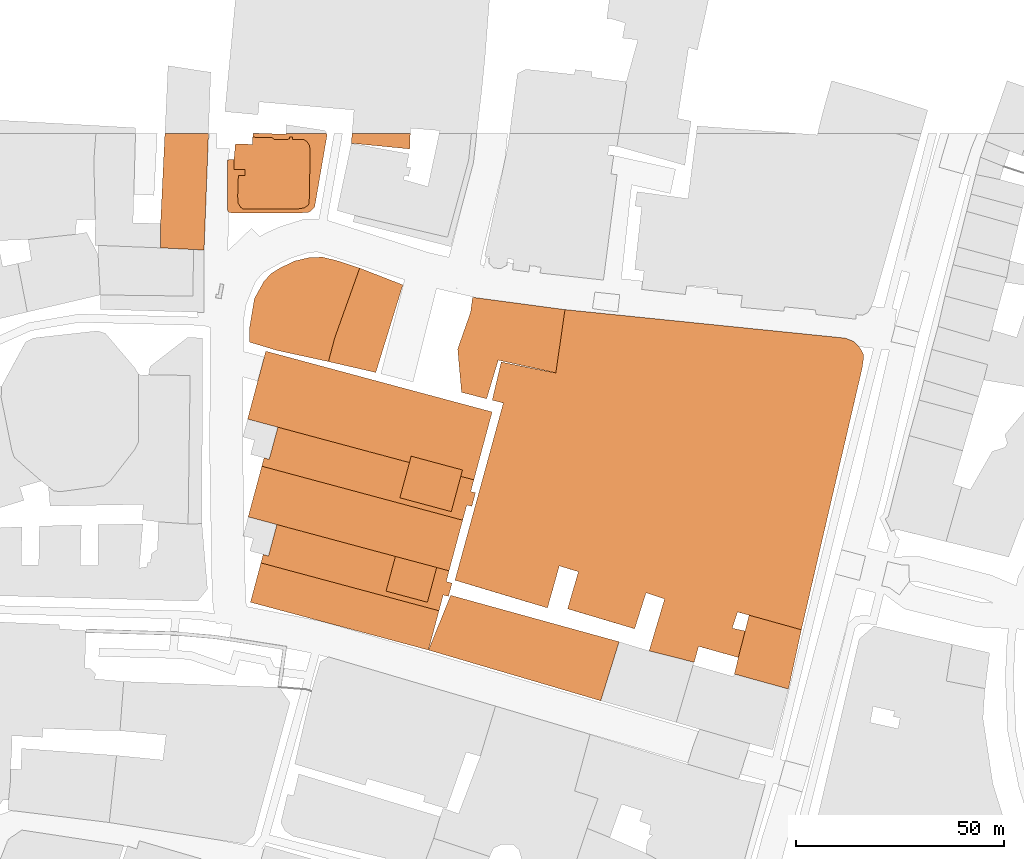
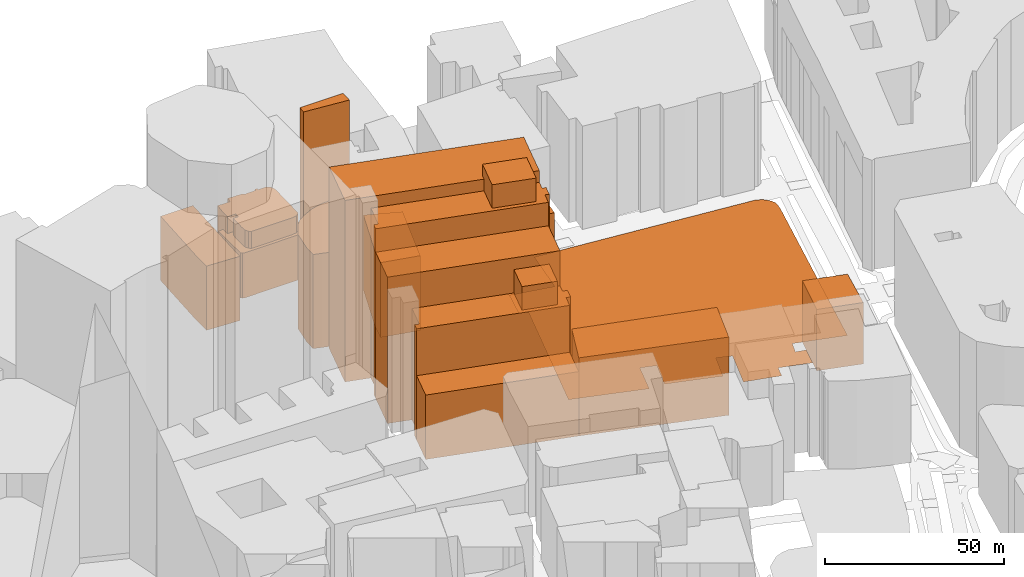
# One storey, part 198 of 200: 18 proxies.
"""IFC4 building model written with IfcOpenShell, lengths in metres."""

from ifc_helpers import new_model, si_unit, origin_with_axes, place, context, subcontext, project, spatial, triangles, material, element, save


model = new_model("IFC4")

# Units and contexts
model_context = context("Model", 3, precision=1e-05, world=origin_with_axes())
body_context = subcontext(model_context, "Body", "Model", "MODEL_VIEW")
ifc_project = project(units=[si_unit("VOLUMEUNIT", "CUBIC_METRE"), si_unit("LENGTHUNIT", "METRE"), si_unit("AREAUNIT", "SQUARE_METRE")], contexts=[model_context])

# Site, building, storey
site_placement = place(None, origin_with_axes())
site = spatial("IfcSite", under=ifc_project, at=site_placement)
building_placement = place(site_placement, origin_with_axes())
building = spatial("IfcBuilding", under=site, at=building_placement, Name="Building")
storey_placement = place(building_placement, origin_with_axes())
storey = spatial("IfcBuildingStorey", under=building, at=storey_placement, Name="Ground")

# Proxies
ifc_material_1 = material()
proxy_1_placement = place(storey_placement, origin_with_axes())
element("IfcBuildingElementProxy", 1, at=proxy_1_placement, inside=storey, material=ifc_material_1, Name="cw_buildings_UK 0", context=body_context, shape_type="Tessellation", body=[
    triangles([(650.4297503117555, -29.812483909174475, 32.16200256347656), (639.4190942642686, -35.550108654849964, 32.16200256347656), (642.6479576232325, -52.182238416089, 32.16200256347656), (662.4392624984657, -32.36771401830046, 32.16200256347656), (643.3216063052685, -32.321255979715424, 32.16200256347656), (636.0043975638723, -46.46786168318051, 32.16200256347656), (656.4693499340494, -49.04630181812453, 32.16200256347656), (653.5192383678722, -29.742815844771403, 32.16200256347656), (646.8524481021273, -30.648766590654102, 32.16200256347656), (641.138057124113, -33.6917871114485, 32.16200256347656), (637.1194011737426, -39.6849120758672, 32.16200256347656), (635.91148029961, -50.16129474416542, 32.16200256347656), (654.9129913963448, -54.8535946282031, 32.16200256347656), (656.8177875976215, -30.53260250071703, 32.16200256347656), (656.4693499340494, -49.04630181812453, 0.0), (662.4392624984657, -32.36771401830046, 0.0), (654.9129913963448, -54.8535946282031, 0.0), (642.6479576232325, -52.182238416089, 0.0), (635.91148029961, -50.16129474416542, 0.0), (636.0043975638723, -46.46786168318051, 0.0), (637.1194011737426, -39.6849120758672, 0.0), (639.4190942642686, -35.550108654849964, 0.0), (641.138057124113, -33.6917871114485, 0.0), (643.3216063052685, -32.321255979715424, 0.0), (646.8524481021273, -30.648766590654102, 0.0), (650.4297503117555, -29.812483909174475, 0.0), (653.5192383678722, -29.742815844771403, 0.0), (656.8177875976215, -30.53260250071703, 0.0)], [[1, 2, 3], [3, 4, 1], [1, 5, 2], [2, 6, 3], [3, 7, 4], [4, 8, 1], [1, 9, 5], [5, 10, 2], [2, 11, 6], [6, 12, 3], [3, 13, 7], [4, 14, 8], [15, 16, 4], [15, 4, 7], [17, 15, 7], [17, 7, 13], [18, 17, 13], [18, 13, 3], [19, 18, 3], [19, 3, 12], [20, 19, 12], [20, 12, 6], [21, 20, 6], [21, 6, 11], [22, 21, 11], [22, 11, 2], [23, 22, 2], [23, 2, 10], [24, 23, 10], [24, 10, 5], [25, 24, 5], [25, 5, 9], [26, 25, 9], [26, 9, 1], [27, 26, 1], [27, 1, 8], [28, 27, 8], [28, 8, 14], [16, 28, 14], [16, 14, 4], [27, 28, 16], [15, 17, 18], [18, 19, 20], [20, 21, 22], [22, 23, 24], [24, 25, 26], [26, 27, 16], [16, 15, 18], [18, 20, 22], [22, 24, 26], [26, 16, 18], [18, 22, 26]], closed=False),
])
proxy_2_placement = place(storey_placement, origin_with_axes())
element("IfcBuildingElementProxy", 2, at=proxy_2_placement, inside=storey, material=ifc_material_1, Name="cw_buildings_UK 1", context=body_context, shape_type="Tessellation", body=[
    triangles([(654.9129913963448, -54.8535946282031, 25.56100082397461), (672.8227290895938, -36.40960136214763, 25.56100082397461), (662.4392624984657, -32.36771401830046, 25.56100082397461), (656.4693499340494, -49.04630181812453, 25.56100082397461), (666.3185419588966, -57.47853078868112, 25.56100082397461), (656.4693499340494, -49.04630181812453, 0.0), (654.9129913963448, -54.8535946282031, 0.0), (662.4392624984657, -32.36771401830046, 0.0), (672.8227290895938, -36.40960136214763, 0.0), (666.3185419588966, -57.47853078868112, 0.0)], [[1, 2, 3], [3, 4, 1], [1, 5, 2], [6, 7, 1], [6, 1, 4], [8, 6, 4], [8, 4, 3], [9, 8, 3], [9, 3, 2], [10, 9, 2], [10, 2, 5], [7, 10, 5], [7, 5, 1], [9, 10, 7], [7, 6, 8], [8, 9, 7]], closed=False),
])
proxy_3_placement = place(storey_placement, origin_with_axes())
element("IfcBuildingElementProxy", 3, at=proxy_3_placement, inside=storey, material=ifc_material_1, Name="cw_buildings_UK 2", context=body_context, shape_type="Tessellation", body=[
    triangles([(689.1064188130765, -42.96026077653575, 25.11414337158203), (686.9228720061053, -62.240498737121875, 25.11414337158203), (695.7499800595289, -54.5051783322898, 25.11414337158203), (711.8013748417177, -42.3562682879813, 25.11414337158203), (685.9937017376674, -51.833822120175704, 25.11414337158203), (692.962469254215, -63.79686202319509, 25.11414337158203), (709.5945990154539, -57.57144686585119, 25.11414337158203), (689.5710039472955, -39.38295381853895, 25.11414337158203), (709.5945990154539, -57.57144686585119, 0.0), (711.8013748417177, -42.3562682879813, 0.0), (695.7499800595289, -54.5051783322898, 0.0), (692.962469254215, -63.79686202319509, 0.0), (686.9228720061053, -62.240498737121875, 0.0), (685.9937017376674, -51.833822120175704, 0.0), (689.1064188130765, -42.96026077653575, 0.0), (689.5710039472955, -39.38295381853895, 0.0)], [[1, 2, 3], [3, 4, 1], [1, 5, 2], [2, 6, 3], [3, 7, 4], [4, 8, 1], [9, 10, 4], [9, 4, 7], [11, 9, 7], [11, 7, 3], [12, 11, 3], [12, 3, 6], [13, 12, 6], [13, 6, 2], [14, 13, 2], [14, 2, 5], [15, 14, 5], [15, 5, 1], [16, 15, 1], [16, 1, 8], [10, 16, 8], [10, 8, 4], [15, 16, 10], [10, 9, 11], [11, 12, 13], [13, 14, 15], [15, 10, 11], [11, 13, 15]], closed=False),
])
proxy_4_placement = place(storey_placement, origin_with_axes())
element("IfcBuildingElementProxy", 4, at=proxy_4_placement, inside=storey, material=ifc_material_1, Name="cw_buildings_UK 11", context=body_context, shape_type="Tessellation", body=[
    triangles([(650.545895408218, -3.9351284956151913, 21.185001373291016), (636.6315870202311, -2.6110554024671604, 21.185001373291016), (634.8893951410942, -10.13733362714105, 21.185001373291016), (633.1007440362802, -15.108381742688952, 21.185001373291016), (645.5283821315322, -1.3799363734381682, 21.185001373291016), (634.8893951410942, -8.67388641823791, 21.185001373291016), (647.5957838420408, -18.151440250432312, 21.185001373291016), (646.3181759100307, -1.426394412023205, 21.185001373291016), (642.0207681668737, -1.4960624764262775, 21.185001373291016), (632.2180329935193, -6.234820399048995, 21.185001373291016), (633.820849569809, -17.756527928985015, 21.185001373291016), (649.9651651775365, -17.291947543134647, 21.185001373291016), (649.7561016297195, -1.9606428622766452, 21.185001373291016), (646.3181759100307, -0.8921079748207993, 21.185001373291016), (641.3935787105149, -1.0314820905759097, 21.185001373291016), (632.5432428248911, -2.541387338064088, 21.185001373291016), (632.2412620128118, -8.604218353834836, 21.185001373291016), (633.2633483584199, -10.13733362714105, 21.185001373291016), (633.2401193391274, -16.780909118699242, 21.185001373291016), (634.4712680454602, -18.221108314835384, 21.185001373291016), (649.1289133604529, -17.895902044740126, 21.185001373291016), (650.290373821816, -16.850577183102313, 21.185001373291016), (650.3136028411086, -2.8201355695743087, 21.185001373291016), (648.9430788319285, -1.426394412023205, 21.185001373291016), (645.5283821315322, -0.8921079748207993, 21.185001373291016), (636.7245042844934, -0.8921079748207993, 21.185001373291016), (641.3935787105149, -1.0314820905759097, 0.0), (636.7245042844934, -0.8921079748207993, 0.0), (642.0207681668737, -1.4960624764262775, 0.0), (645.5283821315322, -1.3799363734381682, 0.0), (645.5283821315322, -0.8921079748207993, 0.0), (646.3181759100307, -0.8921079748207993, 0.0), (646.3181759100307, -1.426394412023205, 0.0), (648.9430788319285, -1.426394412023205, 0.0), (649.7561016297195, -1.9606428622766452, 0.0), (650.3136028411086, -2.8201355695743087, 0.0), (650.545895408218, -3.9351284956151913, 0.0), (650.290373821816, -16.850577183102313, 0.0), (649.9651651775365, -17.291947543134647, 0.0), (649.1289133604529, -17.895902044740126, 0.0), (647.5957838420408, -18.151440250432312, 0.0), (634.4712680454602, -18.221108314835384, 0.0), (633.820849569809, -17.756527928985015, 0.0), (633.2401193391274, -16.780909118699242, 0.0), (633.1007440362802, -15.108381742688952, 0.0), (633.2633483584199, -10.13733362714105, 0.0), (634.8893951410942, -10.13733362714105, 0.0), (634.8893951410942, -8.67388641823791, 0.0), (632.2412620128118, -8.604218353834836, 0.0), (632.2180329935193, -6.234820399048995, 0.0), (632.5432428248911, -2.541387338064088, 0.0), (636.6315870202311, -2.6110554024671604, 0.0)], [[1, 2, 3], [3, 4, 1], [1, 5, 2], [2, 6, 3], [4, 7, 1], [1, 8, 5], [5, 9, 2], [2, 10, 6], [4, 11, 7], [7, 12, 1], [1, 13, 8], [8, 14, 5], [9, 15, 2], [2, 16, 10], [10, 17, 6], [3, 18, 4], [4, 19, 11], [11, 20, 7], [7, 21, 12], [12, 22, 1], [1, 23, 13], [13, 24, 8], [14, 25, 5], [15, 26, 2], [27, 28, 26], [27, 26, 15], [29, 27, 15], [29, 15, 9], [30, 29, 9], [30, 9, 5], [31, 30, 5], [31, 5, 25], [32, 31, 25], [32, 25, 14], [33, 32, 14], [33, 14, 8], [34, 33, 8], [34, 8, 24], [35, 34, 24], [35, 24, 13], [36, 35, 13], [36, 13, 23], [37, 36, 23], [37, 23, 1], [38, 37, 1], [38, 1, 22], [39, 38, 22], [39, 22, 12], [40, 39, 12], [40, 12, 21], [41, 40, 21], [41, 21, 7], [42, 41, 7], [42, 7, 20], [43, 42, 20], [43, 20, 11], [44, 43, 11], [44, 11, 19], [45, 44, 19], [45, 19, 4], [46, 45, 4], [46, 4, 18], [47, 46, 18], [47, 18, 3], [48, 47, 3], [48, 3, 6], [49, 48, 6], [49, 6, 17], [50, 49, 17], [50, 17, 10], [51, 50, 10], [51, 10, 16], [52, 51, 16], [52, 16, 2], [28, 52, 2], [28, 2, 26], [52, 28, 27], [30, 31, 32], [33, 34, 35], [35, 36, 37], [37, 38, 39], [39, 40, 41], [41, 42, 43], [43, 44, 45], [45, 46, 47], [48, 49, 50], [50, 51, 52], [52, 27, 29], [30, 32, 33], [33, 35, 37], [37, 39, 41], [41, 43, 45], [48, 50, 52], [52, 29, 30], [30, 33, 37], [37, 41, 45], [47, 48, 52], [52, 30, 37], [37, 45, 47], [47, 52, 37]], closed=False),
])
proxy_5_placement = place(storey_placement, origin_with_axes())
element("IfcBuildingElementProxy", 5, at=proxy_5_placement, inside=storey, material=ifc_material_1, Name="cw_buildings_UK 83", context=body_context, shape_type="Tessellation", body=[
    triangles([(684.3211981035001, -111.03930907361229, 26.692001342773438), (678.9784761825347, -124.21028647005436, 26.692001342773438), (720.3961879538474, -136.4056355594734, 26.692001342773438), (724.8097491031122, -122.2125718174233, 26.692001342773438), (678.9784761825347, -124.21028647005436, 0.0), (720.3961879538474, -136.4056355594734, 0.0), (684.3211981035001, -111.03930907361229, 0.0), (724.8097491031122, -122.2125718174233, 0.0)], [[1, 2, 3], [3, 4, 1], [5, 6, 3], [5, 3, 2], [7, 5, 2], [7, 2, 1], [8, 7, 1], [8, 1, 4], [6, 8, 4], [6, 4, 3], [7, 8, 6], [6, 5, 7]], closed=False),
])
proxy_6_placement = place(storey_placement, origin_with_axes())
element("IfcBuildingElementProxy", 6, at=proxy_6_placement, inside=storey, material=ifc_material_1, Name="cw_buildings_UK 85", context=body_context, shape_type="Tessellation", body=[
    triangles([(755.1006656659362, -119.63413168247926, 20.970001220703125), (752.5222160342548, -129.97113073828513, 20.970001220703125), (768.6433073710584, -119.33214493493928, 20.970001220703125), (756.0762939729591, -115.82453453155729, 20.970001220703125), (753.4978443412779, -125.99893994905275, 20.970001220703125), (765.5305902956493, -133.57166671557445, 20.970001220703125), (753.4978443412779, -125.99893994905275, 0.0), (752.5222160342548, -129.97113073828513, 0.0), (755.1006656659362, -119.63413168247926, 0.0), (756.0762939729591, -115.82453453155729, 0.0), (768.6433073710584, -119.33214493493928, 0.0), (765.5305902956493, -133.57166671557445, 0.0)], [[1, 2, 3], [3, 4, 1], [1, 5, 2], [2, 6, 3], [7, 8, 2], [7, 2, 5], [9, 7, 5], [9, 5, 1], [10, 9, 1], [10, 1, 4], [11, 10, 4], [11, 4, 3], [12, 11, 3], [12, 3, 6], [8, 12, 6], [8, 6, 2], [11, 12, 8], [8, 7, 9], [9, 10, 11], [11, 8, 9]], closed=False),
])
ifc_material_2 = material(Name="OSM buildings")
proxy_7_placement = place(storey_placement, origin_with_axes())
element("IfcBuildingElementProxy", 7, at=proxy_7_placement, inside=storey, material=ifc_material_2, Name="cw_buildings_ buildings_5", context=body_context, shape_type="Tessellation", body=[
    triangles([(678.7229522219484, -112.7118174561481, 46.0), (680.9529570675046, -104.34929453694355, 46.0), (671.0340756105954, -101.70116259575335, 46.0), (668.7808417457467, -110.04045174729676, 46.0), (680.9529570675046, -104.34929453694355, 0.0), (671.0340756105954, -101.70116259575335, 0.0), (678.7229522219484, -112.7118174561481, 0.0), (668.7808417457467, -110.04045174729676, 0.0)], [[1, 2, 3], [3, 4, 1], [5, 6, 3], [5, 3, 2], [7, 5, 2], [7, 2, 1], [8, 7, 1], [8, 1, 4], [6, 8, 4], [6, 4, 3], [7, 8, 6], [6, 5, 7]], closed=False),
])
proxy_8_placement = place(storey_placement, origin_with_axes())
element("IfcBuildingElementProxy", 8, at=proxy_8_placement, inside=storey, material=ifc_material_2, Name="cw_buildings_ buildings_6", context=body_context, shape_type="Tessellation", body=[
    triangles([(674.402316646591, -79.12235166357478, 66.0), (684.4605722192553, -90.92279792828377, 66.0), (687.1551621990305, -80.91100039420455, 66.0), (674.7972147229324, -77.5892221451627, 66.0), (672.1026199947886, -87.60101967924192, 66.0), (687.1551621990305, -80.91100039420455, 0.0), (674.7972147229324, -77.5892221451627, 0.0), (684.4605722192553, -90.92279792828377, 0.0), (672.1026199947886, -87.60101967924192, 0.0), (674.402316646591, -79.12235166357478, 0.0)], [[1, 2, 3], [3, 4, 1], [1, 5, 2], [6, 7, 4], [6, 4, 3], [8, 6, 3], [8, 3, 2], [9, 8, 2], [9, 2, 5], [10, 9, 5], [10, 5, 1], [7, 10, 1], [7, 1, 4], [8, 9, 10], [10, 7, 6], [6, 8, 10]], closed=False),
])
proxy_9_placement = place(storey_placement, origin_with_axes())
element("IfcBuildingElementProxy", 9, at=proxy_9_placement, inside=storey, material=ifc_material_2, Name="cw_buildings_ buildings_9", context=body_context, shape_type="Tessellation", body=[
    triangles([(638.7222177500322, -56.63645443438197, 62.0), (674.402316646591, -79.12235166357478, 62.0), (689.8962102173907, -83.28038410388453, 62.0), (672.869187128179, -61.21261397032568, 62.0), (637.9556529908263, -59.447191884804106, 62.0), (686.7370351033966, -82.44412991261663, 62.0), (694.2865375989943, -66.95023396763256, 62.0), (639.8604503791951, -52.3390478783171, 62.0), (635.4933543910684, -68.66919801456908, 62.0), (672.869187128179, -61.21261397032568, 0.0), (639.8604503791951, -52.3390478783171, 0.0), (694.2865375989943, -66.95023396763256, 0.0), (689.8962102173907, -83.28038410388453, 0.0), (686.7370351033966, -82.44412991261663, 0.0), (674.402316646591, -79.12235166357478, 0.0), (635.4933543910684, -68.66919801456908, 0.0), (637.9556529908263, -59.447191884804106, 0.0), (638.7222177500322, -56.63645443438197, 0.0)], [[1, 2, 3], [3, 4, 1], [1, 5, 2], [2, 6, 3], [3, 7, 4], [4, 8, 1], [5, 9, 2], [10, 11, 8], [10, 8, 4], [12, 10, 4], [12, 4, 7], [13, 12, 7], [13, 7, 3], [14, 13, 3], [14, 3, 6], [15, 14, 6], [15, 6, 2], [16, 15, 2], [16, 2, 9], [17, 16, 9], [17, 9, 5], [18, 17, 5], [18, 5, 1], [11, 18, 1], [11, 1, 8], [15, 16, 17], [18, 11, 10], [10, 12, 13], [13, 14, 15], [15, 17, 18], [18, 10, 13], [13, 15, 18]], closed=False),
])
proxy_10_placement = place(storey_placement, origin_with_axes())
element("IfcBuildingElementProxy", 10, at=proxy_10_placement, inside=storey, material=ifc_material_2, Name="cw_buildings_ buildings_10", context=body_context, shape_type="Tessellation", body=[
    triangles([(688.200477563931, -89.34321037128666, 58.0), (689.1528768516615, -86.09111918012236, 58.0), (640.6734731769861, -78.35578453018442, 58.0), (638.9080510914646, -80.00505914505909, 58.0), (689.4083960638793, -89.66842138975053, 58.0), (686.7370351033966, -82.44412991261663, 58.0), (639.4423232835611, -78.00734924079666, 58.0), (687.2016202376155, -92.99019963879239, 58.0), (690.2911082937322, -86.36987216000121, 58.0), (689.8962102173907, -83.28038410388453, 58.0), (642.7641027196951, -70.6204498802465, 58.0), (686.7370351033966, -82.44412991261663, 0.0), (642.7641027196951, -70.6204498802465, 0.0), (689.8962102173907, -83.28038410388453, 0.0), (689.1528768516615, -86.09111918012236, 0.0), (690.2911082937322, -86.36987216000121, 0.0), (689.4083960638793, -89.66842138975053, 0.0), (688.200477563931, -89.34321037128666, 0.0), (687.2016202376155, -92.99019963879239, 0.0), (638.9080510914646, -80.00505914505909, 0.0), (639.4423232835611, -78.00734924079666, 0.0), (640.6734731769861, -78.35578453018442, 0.0)], [[1, 2, 3], [3, 4, 1], [1, 5, 2], [2, 6, 3], [3, 7, 4], [4, 8, 1], [5, 9, 2], [2, 10, 6], [6, 11, 3], [12, 13, 11], [12, 11, 6], [14, 12, 6], [14, 6, 10], [15, 14, 10], [15, 10, 2], [16, 15, 2], [16, 2, 9], [17, 16, 9], [17, 9, 5], [18, 17, 5], [18, 5, 1], [19, 18, 1], [19, 1, 8], [20, 19, 8], [20, 8, 4], [21, 20, 4], [21, 4, 7], [22, 21, 7], [22, 7, 3], [13, 22, 3], [13, 3, 11], [22, 13, 12], [12, 14, 15], [15, 16, 17], [18, 19, 20], [20, 21, 22], [22, 12, 15], [15, 17, 18], [18, 20, 22], [22, 15, 18]], closed=False),
])
proxy_11_placement = place(storey_placement, origin_with_axes())
element("IfcBuildingElementProxy", 11, at=proxy_11_placement, inside=storey, material=ifc_material_2, Name="cw_buildings_ buildings_11", context=body_context, shape_type="Tessellation", body=[
    triangles([(680.9529570675046, -104.34929453694355, 50.0), (683.9263000271587, -105.16231970891893, 50.0), (638.9080510914646, -80.00505914505909, 50.0), (671.0340756105954, -101.70116259575335, 50.0), (687.2016202376155, -92.99019963879239, 50.0), (635.6327296939155, -92.17717921518563, 50.0), (687.2016202376155, -92.99019963879239, 0.0), (638.9080510914646, -80.00505914505909, 0.0), (683.9263000271587, -105.16231970891893, 0.0), (680.9529570675046, -104.34929453694355, 0.0), (671.0340756105954, -101.70116259575335, 0.0), (635.6327296939155, -92.17717921518563, 0.0)], [[1, 2, 3], [3, 4, 1], [2, 5, 3], [3, 6, 4], [7, 8, 3], [7, 3, 5], [9, 7, 5], [9, 5, 2], [10, 9, 2], [10, 2, 1], [11, 10, 1], [11, 1, 4], [12, 11, 4], [12, 4, 6], [8, 12, 6], [8, 6, 3], [11, 12, 8], [8, 7, 9], [10, 11, 8], [8, 9, 10]], closed=False),
])
proxy_12_placement = place(storey_placement, origin_with_axes())
element("IfcBuildingElementProxy", 12, at=proxy_12_placement, inside=storey, material=ifc_material_2, Name="cw_buildings_ buildings_12", context=body_context, shape_type="Tessellation", body=[
    triangles([(640.5108688548463, -101.58501749929076, 38.0), (682.5325446245017, -110.96962201573473, 38.0), (683.2526537193071, -107.74075984386295, 38.0), (683.9263000271587, -105.16231970891893, 38.0), (638.6989887307398, -103.25752113345794, 38.0), (683.7869259114036, -111.29483778256723, 38.0), (671.0340756105954, -101.70116259575335, 38.0), (639.2332609228363, -101.23657746153435, 38.0), (681.5104582788937, -114.7559901473642, 38.0), (684.6464043735954, -108.11243364928049, 38.0), (680.9529570675046, -104.34929453694355, 38.0), (642.53181252677, -94.03551500369296, 38.0), (671.0340756105954, -101.70116259575335, 0.0), (642.53181252677, -94.03551500369296, 0.0), (680.9529570675046, -104.34929453694355, 0.0), (683.9263000271587, -105.16231970891893, 0.0), (683.2526537193071, -107.74075984386295, 0.0), (684.6464043735954, -108.11243364928049, 0.0), (683.7869259114036, -111.29483778256723, 0.0), (682.5325446245017, -110.96962201573473, 0.0), (681.5104582788937, -114.7559901473642, 0.0), (638.6989887307398, -103.25752113345794, 0.0), (639.2332609228363, -101.23657746153435, 0.0), (640.5108688548463, -101.58501749929076, 0.0)], [[1, 2, 3], [3, 4, 1], [1, 5, 2], [2, 6, 3], [4, 7, 1], [1, 8, 5], [5, 9, 2], [6, 10, 3], [4, 11, 7], [7, 12, 1], [13, 14, 12], [13, 12, 7], [15, 13, 7], [15, 7, 11], [16, 15, 11], [16, 11, 4], [17, 16, 4], [17, 4, 3], [18, 17, 3], [18, 3, 10], [19, 18, 10], [19, 10, 6], [20, 19, 6], [20, 6, 2], [21, 20, 2], [21, 2, 9], [22, 21, 9], [22, 9, 5], [23, 22, 5], [23, 5, 8], [24, 23, 8], [24, 8, 1], [14, 24, 1], [14, 1, 12], [24, 14, 13], [13, 15, 16], [17, 18, 19], [20, 21, 22], [22, 23, 24], [24, 13, 16], [17, 19, 20], [20, 22, 24], [24, 16, 17], [17, 20, 24]], closed=False),
])
proxy_13_placement = place(storey_placement, origin_with_axes())
element("IfcBuildingElementProxy", 13, at=proxy_13_placement, inside=storey, material=ifc_material_2, Name="cw_buildings_ buildings_13", context=body_context, shape_type="Tessellation", body=[
    triangles([(638.6989887307398, -103.25752113345794, 22.0), (636.1670018860121, -112.7118174561481, 22.0), (678.9784761825347, -124.21028647005436, 22.0), (681.5104582788937, -114.7559901473642, 22.0), (636.1670018860121, -112.7118174561481, 0.0), (678.9784761825347, -124.21028647005436, 0.0), (638.6989887307398, -103.25752113345794, 0.0), (681.5104582788937, -114.7559901473642, 0.0)], [[1, 2, 3], [3, 4, 1], [5, 6, 3], [5, 3, 2], [7, 5, 2], [7, 2, 1], [8, 7, 1], [8, 1, 4], [6, 8, 4], [6, 4, 3], [7, 8, 6], [6, 5, 7]], closed=False),
])
proxy_14_placement = place(storey_placement, origin_with_axes())
element("IfcBuildingElementProxy", 14, at=proxy_14_placement, inside=storey, material=ifc_material_1, Name="cw_buildings_UK 744", context=body_context, shape_type="Tessellation", body=[
    triangles([(660.4183188265422, -2.355555183723941, 0.0), (674.4720037044685, -3.726086315457009, 0.0), (674.4720037044685, -3.726086315457009, 43.28000259399414), (660.4183188265422, -2.355555183723941, 43.28000259399414), (674.6106471948561, 0.0, 43.28000259399414), (674.6106471948561, 0.0, 32.28984050107516), (660.6032021602175, 0.0, 30.52186990377251), (669.674429029803, -4.440892098500626e-16, 0.0), (669.674429029803, 0.0, 43.28000259399414), (660.6032021602175, 0.0, 0.0), (674.6106471948561, -2.220446049250313e-16, 0.0), (660.6032021602175, 0.0, 43.28000259399414)], [[1, 2, 3], [1, 3, 4], [4, 3, 5], [3, 2, 6], [1, 4, 7], [2, 1, 8], [5, 9, 4], [6, 5, 3], [7, 10, 1], [8, 11, 2], [4, 9, 12], [2, 11, 6], [4, 12, 7], [1, 10, 8], [6, 11, 8], [8, 10, 7], [7, 12, 9], [9, 5, 6], [6, 8, 7], [7, 9, 6]], closed=False),
])
proxy_15_placement = place(storey_placement, origin_with_axes())
element("IfcBuildingElementProxy", 15, at=proxy_15_placement, inside=storey, material=ifc_material_1, Name="cw_buildings_UK 751", context=body_context, shape_type="Tessellation", body=[
    triangles([(614.5638180737644, -21.635831131259035, 21.94900131225586), (622.5314439924298, -27.907704327187968, 21.94900131225586), (625.0169717227701, -28.04707844294308, 21.94900131225586), (614.5870470930569, -27.51279200574067, 21.94900131225586), (622.5314439924298, -27.907704327187968, 0.0), (625.0169717227701, -28.04707844294308, 0.0), (614.5870470930569, -27.51279200574067, 0.0), (614.5638180737644, -21.635831131259035, 0.0), (625.320511561298, -3.552713678800501e-15, 21.94900131225586), (626.0822430823828, -3.552713678800501e-15, 14.379445446491951), (615.6020055219403, 0.0, 2.329603898069987), (621.0325443774348, 0.0, 0.0), (621.0325443774348, 0.0, 21.94900131225586), (626.0822430823828, 0.0, 21.94900131225586), (615.6020055219403, -4.440892098500626e-16, 0.0), (625.320511561298, 0.0, 0.0), (615.6020055219403, -4.440892098500626e-16, 21.94900131225586), (626.0822430823828, -3.552713678800501e-15, 0.0)], [[1, 2, 3], [1, 4, 2], [5, 6, 3], [5, 3, 2], [7, 5, 2], [7, 2, 4], [8, 7, 4], [8, 4, 1], [5, 7, 8], [6, 5, 8], [1, 3, 9], [3, 6, 10], [8, 1, 11], [6, 8, 12], [9, 13, 1], [10, 14, 3], [11, 15, 8], [12, 16, 6], [1, 13, 17], [3, 14, 9], [6, 18, 10], [1, 17, 11], [6, 16, 18], [8, 15, 12], [10, 18, 16], [12, 15, 11], [11, 17, 13], [9, 14, 10], [10, 16, 12], [12, 11, 13], [13, 9, 10], [10, 12, 13]], closed=False),
])
proxy_16_placement = place(storey_placement, origin_with_axes())
element("IfcBuildingElementProxy", 16, at=proxy_16_placement, inside=storey, material=ifc_material_1, Name="cw_buildings_UK 753", context=body_context, shape_type="Tessellation", body=[
    triangles([(650.290373821816, -16.850577183102313, 15.411001205444336), (649.9651651775365, -17.291947543134647, 15.411001205444336), (650.7317299367426, -18.616020636282677, 15.411001205444336), (654.5877827520652, -0.4507376147884669, 15.411001205444336), (649.1289133604529, -17.895902044740126, 15.411001205444336), (650.545895408218, -3.9351284956151913, 15.411001205444336), (647.5957838420408, -18.151440250432312, 15.411001205444336), (650.3136028411086, -2.8201355695743087, 15.411001205444336), (634.4712680454602, -18.221108314835384, 15.411001205444336), (649.7561016297195, -1.9606428622766452, 15.411001205444336), (630.6849040686533, -18.54631458493064, 15.411001205444336), (648.9430788319285, -1.426394412023205, 15.411001205444336), (633.820849569809, -17.756527928985015, 15.411001205444336), (644.7153593337412, -0.19523739604524745, 15.411001205444336), (633.2401193391274, -16.780909118699242, 15.411001205444336), (646.3181759100307, -0.8921079748207993, 15.411001205444336), (633.1007440362802, -15.108381742688952, 15.411001205444336), (645.5283821315322, -0.8921079748207993, 15.411001205444336), (632.2412620128118, -8.604218353834836, 15.411001205444336), (641.3935787105149, -1.0314820905759097, 15.411001205444336), (633.2633483584199, -10.13733362714105, 15.411001205444336), (632.2180329935193, -6.234820399048995, 15.411001205444336), (631.7999070849776, -19.15026908653612, 15.411001205444336), (642.0207681668737, -1.4960624764262775, 15.411001205444336), (634.8893951410942, -10.13733362714105, 15.411001205444336), (630.6152164172297, -6.35098448898607, 15.411001205444336), (631.0798009579026, -18.964436932195973, 15.411001205444336), (649.849020081074, -19.057353009366047, 15.411001205444336), (651.6144397924112, -17.71006989039998, 15.411001205444336), (645.5283821315322, -1.3799363734381682, 15.411001205444336), (646.3181759100307, -1.426394412023205, 15.411001205444336), (634.8893951410942, -8.67388641823791, 15.411001205444336), (634.8893951410942, -10.13733362714105, 0.0), (634.8893951410942, -8.67388641823791, 0.0), (633.2633483584199, -10.13733362714105, 0.0), (633.1007440362802, -15.108381742688952, 0.0), (633.2401193391274, -16.780909118699242, 0.0), (633.820849569809, -17.756527928985015, 0.0), (634.4712680454602, -18.221108314835384, 0.0), (647.5957838420408, -18.151440250432312, 0.0), (649.1289133604529, -17.895902044740126, 0.0), (649.9651651775365, -17.291947543134647, 0.0), (650.290373821816, -16.850577183102313, 0.0), (650.545895408218, -3.9351284956151913, 0.0), (650.3136028411086, -2.8201355695743087, 0.0), (649.7561016297195, -1.9606428622766452, 0.0), (648.9430788319285, -1.426394412023205, 0.0), (646.3181759100307, -1.426394412023205, 0.0), (646.3181759100307, -0.8921079748207993, 0.0), (645.5283821315322, -0.8921079748207993, 0.0), (645.5283821315322, -1.3799363734381682, 0.0), (642.0207681668737, -1.4960624764262775, 0.0), (641.3935787105149, -1.0314820905759097, 0.0), (636.7245042844934, -0.8921079748207993, 0.0), (636.7245042844934, -0.8921079748207993, 15.411001205444336), (651.6144397924112, -17.71006989039998, 0.0), (654.5877827520652, -0.4507376147884669, 0.0), (650.7317299367426, -18.616020636282677, 0.0), (649.849020081074, -19.057353009366047, 0.0), (631.7999070849776, -19.15026908653612, 0.0), (631.0798009579026, -18.964436932195973, 0.0), (630.6849040686533, -18.54631458493064, 0.0), (630.6152164172297, -6.35098448898607, 0.0), (632.2180329935193, -6.234820399048995, 0.0), (632.2412620128118, -8.604218353834836, 0.0), (644.7153593337412, -0.19523739604524745, 0.0), (654.3668266884667, -5.551115123125783e-17, 15.411001205444336), (639.5793902119277, 0.0, 15.411001205444336), (637.2045306340705, 0.0, 15.411001205444336), (636.7659968896733, -1.1102230246251565e-16, 1.647127225395776), (639.5793902119277, 0.0, 9.963050212767367), (644.7153593337412, -2.7755575615628914e-17, 14.115744395392161), (654.5011006696502, -5.551115123125783e-17, 11.501392747928747), (636.7659968896733, 1.3877787807814457e-17, 0.0), (637.2045306340705, 0.0, 0.0), (646.6677507546108, 0.0, 0.0), (646.6677507546108, 0.0, 15.411001205444336), (636.7659968896733, 1.3877787807814457e-17, 15.411001205444336), (644.7153593337412, 0.0, 0.0), (654.5011006696502, 0.0, 15.411001205444336), (639.5793902119277, 0.0, 0.0), (654.3668266884667, 0.0, 0.0), (644.7153593337412, 0.0, 15.411001205444336), (654.5011006696502, -5.551115123125783e-17, 0.0)], [[1, 2, 3], [3, 4, 1], [2, 5, 3], [4, 6, 1], [5, 7, 3], [4, 8, 6], [7, 9, 3], [4, 10, 8], [9, 11, 3], [4, 12, 10], [9, 13, 11], [4, 14, 12], [13, 15, 11], [14, 16, 12], [15, 17, 11], [14, 18, 16], [17, 19, 11], [14, 20, 18], [17, 21, 19], [19, 22, 11], [11, 23, 3], [20, 24, 18], [21, 25, 19], [22, 26, 11], [11, 27, 23], [23, 28, 3], [3, 29, 4], [24, 30, 18], [16, 31, 12], [25, 32, 19], [33, 34, 32], [33, 32, 25], [35, 33, 25], [35, 25, 21], [36, 35, 21], [36, 21, 17], [37, 36, 17], [37, 17, 15], [38, 37, 15], [38, 15, 13], [39, 38, 13], [39, 13, 9], [40, 39, 9], [40, 9, 7], [41, 40, 7], [41, 7, 5], [42, 41, 5], [42, 5, 2], [43, 42, 2], [43, 2, 1], [44, 43, 1], [44, 1, 6], [45, 44, 6], [45, 6, 8], [46, 45, 8], [46, 8, 10], [47, 46, 10], [47, 10, 12], [48, 47, 12], [48, 12, 31], [49, 48, 31], [49, 31, 16], [50, 49, 16], [50, 16, 18], [51, 50, 18], [51, 18, 30], [52, 51, 30], [52, 30, 24], [53, 52, 24], [53, 24, 20], [54, 53, 20], [54, 20, 55], [56, 57, 4], [56, 4, 29], [58, 56, 29], [58, 29, 3], [59, 58, 3], [59, 3, 28], [60, 59, 28], [60, 28, 23], [61, 60, 23], [61, 23, 27], [62, 61, 27], [62, 27, 11], [63, 62, 11], [63, 11, 26], [64, 63, 26], [64, 26, 22], [65, 64, 22], [65, 22, 19], [34, 65, 19], [34, 19, 32], [65, 34, 33], [47, 48, 49], [50, 51, 52], [57, 56, 58], [58, 59, 60], [60, 61, 62], [62, 63, 64], [65, 33, 35], [50, 52, 53], [58, 60, 62], [62, 64, 65], [65, 35, 36], [50, 53, 66], [62, 65, 36], [49, 50, 66], [62, 36, 37], [47, 49, 66], [62, 37, 38], [47, 66, 57], [62, 38, 39], [46, 47, 57], [58, 62, 39], [45, 46, 57], [58, 39, 40], [44, 45, 57], [58, 40, 41], [43, 44, 57], [58, 41, 42], [43, 57, 58], [58, 42, 43], [14, 4, 67], [20, 14, 68], [55, 20, 69], [54, 55, 70], [14, 66, 71], [66, 14, 72], [4, 57, 73], [53, 54, 74], [66, 53, 75], [57, 66, 76], [67, 77, 14], [68, 69, 20], [69, 78, 55], [70, 74, 54], [71, 68, 14], [72, 79, 66], [73, 80, 4], [74, 75, 53], [75, 81, 66], [76, 82, 57], [4, 80, 67], [14, 77, 83], [55, 78, 70], [66, 81, 71], [14, 83, 72], [57, 84, 73], [66, 79, 76], [57, 82, 84], [69, 68, 71], [71, 81, 75], [75, 74, 70], [70, 78, 69], [69, 71, 75], [75, 70, 69], [76, 79, 72], [72, 83, 77], [67, 80, 73], [73, 84, 82], [82, 76, 72], [72, 77, 67], [67, 73, 82], [82, 72, 67]], closed=False),
])
ifc_material_3 = material(Name="buildingConstruction")
proxy_17_placement = place(storey_placement, origin_with_axes())
element("IfcBuildingElementProxy", 17, at=proxy_17_placement, inside=storey, material=ifc_material_3, Name="cw_surface_buildingConstruction_0", ObjectType="Building Construction", context=body_context, shape_type="Tessellation", body=[
    triangles([(753.2887831676452, -115.06378243864525, 0.0), (696.9811275787696, -64.8189388720659, 0.0), (731.2907024661482, -110.44115061901064, 0.0), (735.7507121572608, -111.92784584068079, 0.0), (781.9768879025481, -50.74203921995286, 0.0), (715.0302370135895, -105.37718642629267, 0.0), (743.9274029221251, -123.31014126791273, 0.0), (773.8931132148539, -96.64299919840782, 0.0), (709.5945990154539, -57.57144686585119, 0.0), (710.4308532067218, -103.98344526874156, 0.0), (751.9879485905269, -118.94304765397031, 0.0), (783.5564612144394, -53.1114371747387, 0.0), (779.1429190586492, -49.20892394664664, 0.0), (696.4700844059655, -54.94651070537317, 0.0), (685.3432844491082, -107.42137811098326, 0.0), (712.4285678593529, -114.29720580851766, 0.0), (732.034040580246, -124.42517218090258, 0.0), (753.4978443412779, -126.00474549279383, 0.0), (756.0762939729591, -115.83035906877285, 0.0), (783.2312549443442, -56.54933203003142, 0.0), (782.906048674249, -51.810574107408705, 0.0), (781.094166175958, -49.95225256400723, 0.0), (711.8013748417177, -42.3562682879813, 0.0), (694.3097666182869, -64.12206829329035, 0.0), (707.596884362823, -114.08816362835948, 0.0), (728.5496496994193, -119.10566978249243, 0.0), (742.8588585379321, -127.14298643160171, 0.0), (755.1006656659362, -119.63991823274586, 0.0), (768.6433073710584, -119.3379599754176, 0.0), (783.5100031758544, -54.69101048662995, 0.0)], [[1, 2, 3], [3, 4, 1], [1, 5, 2], [2, 6, 3], [4, 7, 1], [1, 8, 5], [5, 9, 2], [2, 10, 6], [7, 11, 1], [8, 12, 5], [5, 13, 9], [9, 14, 2], [2, 15, 10], [6, 16, 3], [4, 17, 7], [7, 18, 11], [1, 19, 8], [8, 20, 12], [12, 21, 5], [5, 22, 13], [13, 23, 9], [14, 24, 2], [15, 25, 10], [16, 26, 3], [17, 27, 7], [18, 28, 11], [19, 29, 8], [20, 30, 12]], closed=True),
])
proxy_18_placement = place(storey_placement, origin_with_axes())
element("IfcBuildingElementProxy", 18, at=proxy_18_placement, inside=storey, material=ifc_material_3, Name="cw_surface_buildingConstruction_1", ObjectType="Building Construction", context=body_context, shape_type="Tessellation", body=[
    triangles([(753.2887831676452, -115.05796739816694, 0.0), (696.9811275787696, -64.81314519924638, 0.0), (731.2907024661482, -110.43535457200682, 0.0), (735.7507121572608, -111.92202130346523, 0.0), (781.9768879025481, -50.73623130202747, 0.0), (715.0302370135895, -105.37138088255159, 0.0), (743.9274029221251, -123.3043452209089, 0.0), (773.8931132148539, -96.63718890629812, 0.0), (709.5945990154539, -57.565624702819946, 0.0), (710.4308532067218, -103.97762547989463, 0.0), (751.9879485905269, -118.93725160696647, 0.0), (783.5564612144394, -53.10561263752314, 0.0), (779.1429190586492, -49.203101783615395, 0.0), (696.4700844059655, -54.94072178092227, 0.0), (685.3432844491082, -107.4155535737677, 0.0), (712.4285678593529, -114.29140026477658, 0.0), (732.034040580246, -124.41934764368702, 0.0), (753.4978443412779, -125.99893994905275, 0.0), (756.0762939729591, -115.82453453155729, 0.0), (783.2312549443442, -56.543538357211894, 0.0), (782.906048674249, -51.80477568622056, 0.0), (781.094166175958, -49.946437523528914, 0.0), (711.8013748417177, -42.350478176438244, 0.0), (694.3097666182869, -64.11626749791789, 0.0), (707.596884362823, -114.08233909114392, 0.0), (728.5496496994193, -119.0998547420141, 0.0), (742.8588585379321, -127.1371713911234, 0.0), (755.1006656659362, -119.63413168247926, 0.0), (768.6433073710584, -119.33214493493928, 0.0), (783.5100031758544, -54.68520019452025, 0.0)], [[1, 2, 3], [3, 4, 1], [1, 5, 2], [2, 6, 3], [4, 7, 1], [1, 8, 5], [5, 9, 2], [2, 10, 6], [7, 11, 1], [8, 12, 5], [5, 13, 9], [9, 14, 2], [2, 15, 10], [6, 16, 3], [4, 17, 7], [7, 18, 11], [1, 19, 8], [8, 20, 12], [12, 21, 5], [5, 22, 13], [13, 23, 9], [14, 24, 2], [15, 25, 10], [16, 26, 3], [17, 27, 7], [18, 28, 11], [19, 29, 8], [20, 30, 12]], closed=True),
])

save(model, "model.ifc")
